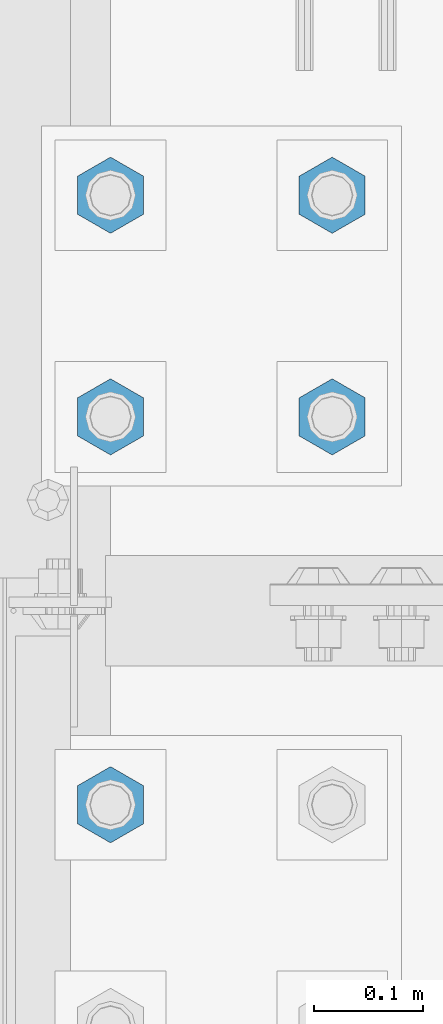
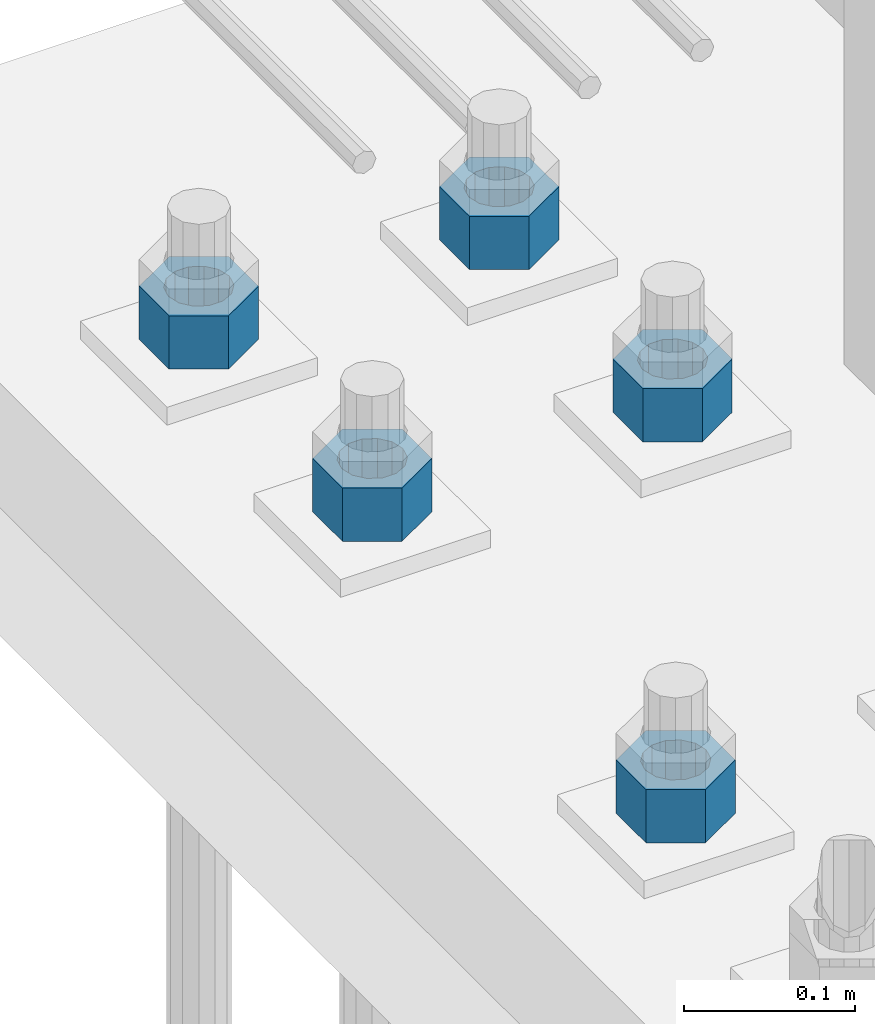
# One storey, part 1660 of 3843: 5 columns, 1 element without a shape of its own.
"""IFC2X3 building model written with IfcOpenShell, lengths in millimetres."""

from ifc_helpers import new_model, si_unit, frame, origin_with_axes, place, context, subcontext, project, spatial, faceted_brep, material, type_object, element, aggregate, save


model = new_model("IFC2X3")

# Units and contexts
model_context = context("Model", 3, precision=1e-05, world=origin_with_axes())
body_context = subcontext(model_context, "Body", "Model", "MODEL_VIEW")
ifc_project = project(units=[si_unit("LENGTHUNIT", "METRE", prefix="MILLI"), si_unit("AREAUNIT", "SQUARE_METRE"), si_unit("VOLUMEUNIT", "CUBIC_METRE"), si_unit("MASSUNIT", "GRAM", prefix="KILO"), si_unit("TIMEUNIT", "SECOND"), si_unit("PLANEANGLEUNIT", "RADIAN"), si_unit("SOLIDANGLEUNIT", "STERADIAN"), si_unit("THERMODYNAMICTEMPERATUREUNIT", "DEGREE_CELSIUS"), si_unit("LUMINOUSINTENSITYUNIT", "LUMEN")], contexts=[model_context])

# Site, building, storey
site_placement = place(None, origin_with_axes())
site = spatial("IfcSite", under=ifc_project, at=site_placement, CompositionType="ELEMENT")
building_placement = place(site_placement, origin_with_axes())
building = spatial("IfcBuilding", under=site, at=building_placement, Name="Undefined", CompositionType="ELEMENT")
storey_placement = place(building_placement, origin_with_axes())
storey = spatial("IfcBuildingStorey", under=building, at=storey_placement, Name="Undefined", CompositionType="ELEMENT", Elevation=0.0)

# Assembly, columns
assembly_placement = place(storey_placement, origin_with_axes())
assembly = element("IfcElementAssembly", 1, at=assembly_placement, inside=storey, Name="TEMPLATE", AssemblyPlace="NOTDEFINED", PredefinedType="RIGID_FRAME")
ifc_material = material(Name="STEEL/A572-50")
column_type = type_object("IfcColumnType", Name="1-1/2_HEAVY_HEX_NUT", PredefinedType="NOTDEFINED")
column_1_placement = place(assembly_placement, frame((76708.0, 15176.5, 30200.6), z_axis=(-1.0, 0.0, 0.0), x_axis=(0.0, 0.0, -1.0)))
column_1 = element("IfcColumn", 2, at=column_1_placement, type_object=column_type, material=ifc_material, Name="NUT", ObjectType="1-1/2_HEAVY_HEX_NUT", context=body_context, shape_type="Brep", body=[
    faceted_brep([(0.0, -34.9199981689453, 0.0), (0.0, -17.4599990844727, -30.25), (38.0999999999985, -17.4599990844727, -30.25), (38.0999999999985, -34.9199981689453, 0.0), (0.0, 17.4599990844727, -30.25), (38.0999999999985, 17.4599990844727, -30.25), (0.0, 34.9199981689453, 0.0), (38.0999999999985, 34.9199981689453, 0.0), (0.0, 17.4599990844727, 30.25), (38.0999999999985, 17.4599990844727, 30.25), (0.0, -17.4599990844727, 30.25), (38.0999999999985, -17.4599990844727, 30.25), (0.0, 0.0, 20.6399993896484), (0.0, 8.9553601105581, 18.5959968835959), (38.0999999999985, 8.9553601105581, 18.5959968835959), (38.0999999999985, 0.0, 20.6399993896484), (0.0, 16.1370013209525, 12.8688291298167), (38.0999999999985, 16.1370013209525, 12.8688291298167), (0.0, 20.1225115123816, 4.59283194104501), (38.0999999999985, 20.1225115123816, 4.59283194104501), (0.0, 20.1225115123816, -4.59283194104501), (38.0999999999985, 20.1225115123816, -4.59283194104501), (0.0, 16.1370013209525, -12.8688291298167), (38.0999999999985, 16.1370013209525, -12.8688291298167), (0.0, 8.9553601105581, -18.5959968835959), (38.0999999999985, 8.9553601105581, -18.5959968835959), (0.0, 0.0, -20.6399993896484), (38.0999999999985, 0.0, -20.6399993896484), (0.0, -8.9553601105581, -18.5959968835959), (38.0999999999985, -8.9553601105581, -18.5959968835959), (0.0, -16.1370013209525, -12.8688291298167), (38.0999999999985, -16.1370013209525, -12.8688291298167), (0.0, -20.1225115123816, -4.59283194104501), (38.0999999999985, -20.1225115123816, -4.59283194104501), (0.0, -20.1225115123816, 4.59283194104501), (38.0999999999985, -20.1225115123816, 4.59283194104501), (0.0, -16.1370013209525, 12.8688291298167), (38.0999999999985, -16.1370013209525, 12.8688291298167), (0.0, -8.9553601105581, 18.5959968835959), (38.0999999999985, -8.9553601105581, 18.5959968835959)], [[[0, 1, 2, 3]], [[1, 4, 5, 2]], [[4, 6, 7, 5]], [[6, 8, 9, 7]], [[8, 10, 11, 9]], [[10, 0, 3, 11]], [[12, 13, 14, 15]], [[13, 16, 17, 14]], [[16, 18, 19, 17]], [[18, 20, 21, 19]], [[20, 22, 23, 21]], [[22, 24, 25, 23]], [[24, 26, 27, 25]], [[26, 28, 29, 27]], [[28, 30, 31, 29]], [[30, 32, 33, 31]], [[32, 34, 35, 33]], [[34, 36, 37, 35]], [[36, 38, 39, 37]], [[38, 12, 15, 39]], [[5, 7, 9, 11, 3, 2], [17, 19, 21, 23, 25, 27, 29, 31, 33, 35, 37, 39, 15, 14]], [[10, 8, 6, 4, 1, 0], [38, 36, 34, 32, 30, 28, 26, 24, 22, 20, 18, 16, 13, 12]]]),
])
column_2_placement = place(assembly_placement, frame((76708.0, 15379.7, 30200.6), z_axis=(-1.0, 0.0, 0.0), x_axis=(0.0, 0.0, -1.0)))
column_2 = element("IfcColumn", 3, at=column_2_placement, type_object=column_type, material=ifc_material, Name="NUT", ObjectType="1-1/2_HEAVY_HEX_NUT", context=body_context, shape_type="Brep", body=[
    faceted_brep([(0.0, -34.9199981689453, 0.0), (0.0, -17.4599990844727, -30.25), (38.0999999999985, -17.4599990844727, -30.25), (38.0999999999985, -34.9199981689453, 0.0), (0.0, 17.4599990844727, -30.25), (38.0999999999985, 17.4599990844727, -30.25), (0.0, 34.9199981689453, 0.0), (38.0999999999985, 34.9199981689453, 0.0), (0.0, 17.4599990844727, 30.25), (38.0999999999985, 17.4599990844727, 30.25), (0.0, -17.4599990844727, 30.25), (38.0999999999985, -17.4599990844727, 30.25), (0.0, 0.0, 20.6399993896484), (0.0, 8.9553601105581, 18.5959968835959), (38.0999999999985, 8.9553601105581, 18.5959968835959), (38.0999999999985, 0.0, 20.6399993896484), (0.0, 16.1370013209525, 12.8688291298167), (38.0999999999985, 16.1370013209525, 12.8688291298167), (0.0, 20.1225115123816, 4.59283194104501), (38.0999999999985, 20.1225115123816, 4.59283194104501), (0.0, 20.1225115123816, -4.59283194104501), (38.0999999999985, 20.1225115123816, -4.59283194104501), (0.0, 16.1370013209525, -12.8688291298167), (38.0999999999985, 16.1370013209525, -12.8688291298167), (0.0, 8.9553601105581, -18.5959968835959), (38.0999999999985, 8.9553601105581, -18.5959968835959), (0.0, 0.0, -20.6399993896484), (38.0999999999985, 0.0, -20.6399993896484), (0.0, -8.9553601105581, -18.5959968835959), (38.0999999999985, -8.9553601105581, -18.5959968835959), (0.0, -16.1370013209525, -12.8688291298167), (38.0999999999985, -16.1370013209525, -12.8688291298167), (0.0, -20.1225115123816, -4.59283194104501), (38.0999999999985, -20.1225115123816, -4.59283194104501), (0.0, -20.1225115123816, 4.59283194104501), (38.0999999999985, -20.1225115123816, 4.59283194104501), (0.0, -16.1370013209525, 12.8688291298167), (38.0999999999985, -16.1370013209525, 12.8688291298167), (0.0, -8.9553601105581, 18.5959968835959), (38.0999999999985, -8.9553601105581, 18.5959968835959)], [[[0, 1, 2, 3]], [[1, 4, 5, 2]], [[4, 6, 7, 5]], [[6, 8, 9, 7]], [[8, 10, 11, 9]], [[10, 0, 3, 11]], [[12, 13, 14, 15]], [[13, 16, 17, 14]], [[16, 18, 19, 17]], [[18, 20, 21, 19]], [[20, 22, 23, 21]], [[22, 24, 25, 23]], [[24, 26, 27, 25]], [[26, 28, 29, 27]], [[28, 30, 31, 29]], [[30, 32, 33, 31]], [[32, 34, 35, 33]], [[34, 36, 37, 35]], [[36, 38, 39, 37]], [[38, 12, 15, 39]], [[5, 7, 9, 11, 3, 2], [17, 19, 21, 23, 25, 27, 29, 31, 33, 35, 37, 39, 15, 14]], [[10, 8, 6, 4, 1, 0], [38, 36, 34, 32, 30, 28, 26, 24, 22, 20, 18, 16, 13, 12]]]),
])
column_3_placement = place(assembly_placement, frame((76504.8, 14820.9, 30200.6), z_axis=(1.0, 0.0, 0.0), x_axis=(0.0, 0.0, -1.0)))
column_3 = element("IfcColumn", 4, at=column_3_placement, type_object=column_type, material=ifc_material, Name="NUT", ObjectType="1-1/2_HEAVY_HEX_NUT", context=body_context, shape_type="Brep", body=[
    faceted_brep([(0.0, -34.9199981689453, 0.0), (0.0, -17.4599990844727, -30.25), (38.0999999999985, -17.4599990844727, -30.25), (38.0999999999985, -34.9199981689453, 0.0), (0.0, 17.4599990844727, -30.25), (38.0999999999985, 17.4599990844727, -30.25), (0.0, 34.9199981689453, 0.0), (38.0999999999985, 34.9199981689453, 0.0), (0.0, 17.4599990844727, 30.25), (38.0999999999985, 17.4599990844727, 30.25), (0.0, -17.4599990844727, 30.25), (38.0999999999985, -17.4599990844727, 30.25), (0.0, 0.0, 20.6399993896484), (0.0, 8.9553601105581, 18.5959968835959), (38.0999999999985, 8.9553601105581, 18.5959968835959), (38.0999999999985, 0.0, 20.6399993896484), (0.0, 16.1370013209525, 12.8688291298167), (38.0999999999985, 16.1370013209525, 12.8688291298167), (0.0, 20.1225115123816, 4.59283194104501), (38.0999999999985, 20.1225115123816, 4.59283194104501), (0.0, 20.1225115123816, -4.59283194104501), (38.0999999999985, 20.1225115123816, -4.59283194104501), (0.0, 16.1370013209525, -12.8688291298167), (38.0999999999985, 16.1370013209525, -12.8688291298167), (0.0, 8.9553601105581, -18.5959968835959), (38.0999999999985, 8.9553601105581, -18.5959968835959), (0.0, 0.0, -20.6399993896484), (38.0999999999985, 0.0, -20.6399993896484), (0.0, -8.9553601105581, -18.5959968835959), (38.0999999999985, -8.9553601105581, -18.5959968835959), (0.0, -16.1370013209525, -12.8688291298167), (38.0999999999985, -16.1370013209525, -12.8688291298167), (0.0, -20.1225115123816, -4.59283194104501), (38.0999999999985, -20.1225115123816, -4.59283194104501), (0.0, -20.1225115123816, 4.59283194104501), (38.0999999999985, -20.1225115123816, 4.59283194104501), (0.0, -16.1370013209525, 12.8688291298167), (38.0999999999985, -16.1370013209525, 12.8688291298167), (0.0, -8.9553601105581, 18.5959968835959), (38.0999999999985, -8.9553601105581, 18.5959968835959)], [[[0, 1, 2, 3]], [[1, 4, 5, 2]], [[4, 6, 7, 5]], [[6, 8, 9, 7]], [[8, 10, 11, 9]], [[10, 0, 3, 11]], [[12, 13, 14, 15]], [[13, 16, 17, 14]], [[16, 18, 19, 17]], [[18, 20, 21, 19]], [[20, 22, 23, 21]], [[22, 24, 25, 23]], [[24, 26, 27, 25]], [[26, 28, 29, 27]], [[28, 30, 31, 29]], [[30, 32, 33, 31]], [[32, 34, 35, 33]], [[34, 36, 37, 35]], [[36, 38, 39, 37]], [[38, 12, 15, 39]], [[5, 7, 9, 11, 3, 2], [17, 19, 21, 23, 25, 27, 29, 31, 33, 35, 37, 39, 15, 14]], [[10, 8, 6, 4, 1, 0], [38, 36, 34, 32, 30, 28, 26, 24, 22, 20, 18, 16, 13, 12]]]),
])
column_4_placement = place(assembly_placement, frame((76504.8, 15176.5, 30200.6), z_axis=(-1.0, 0.0, 0.0), x_axis=(0.0, 0.0, -1.0)))
column_4 = element("IfcColumn", 5, at=column_4_placement, type_object=column_type, material=ifc_material, Name="NUT", ObjectType="1-1/2_HEAVY_HEX_NUT", context=body_context, shape_type="Brep", body=[
    faceted_brep([(0.0, -34.9199981689453, 0.0), (0.0, -17.4599990844727, -30.25), (38.0999999999985, -17.4599990844727, -30.25), (38.0999999999985, -34.9199981689453, 0.0), (0.0, 17.4599990844727, -30.25), (38.0999999999985, 17.4599990844727, -30.25), (0.0, 34.9199981689453, 0.0), (38.0999999999985, 34.9199981689453, 0.0), (0.0, 17.4599990844727, 30.25), (38.0999999999985, 17.4599990844727, 30.25), (0.0, -17.4599990844727, 30.25), (38.0999999999985, -17.4599990844727, 30.25), (0.0, 0.0, 20.6399993896484), (0.0, 8.9553601105581, 18.5959968835959), (38.0999999999985, 8.9553601105581, 18.5959968835959), (38.0999999999985, 0.0, 20.6399993896484), (0.0, 16.1370013209525, 12.8688291298167), (38.0999999999985, 16.1370013209525, 12.8688291298167), (0.0, 20.1225115123816, 4.59283194104501), (38.0999999999985, 20.1225115123816, 4.59283194104501), (0.0, 20.1225115123816, -4.59283194104501), (38.0999999999985, 20.1225115123816, -4.59283194104501), (0.0, 16.1370013209525, -12.8688291298167), (38.0999999999985, 16.1370013209525, -12.8688291298167), (0.0, 8.9553601105581, -18.5959968835959), (38.0999999999985, 8.9553601105581, -18.5959968835959), (0.0, 0.0, -20.6399993896484), (38.0999999999985, 0.0, -20.6399993896484), (0.0, -8.9553601105581, -18.5959968835959), (38.0999999999985, -8.9553601105581, -18.5959968835959), (0.0, -16.1370013209525, -12.8688291298167), (38.0999999999985, -16.1370013209525, -12.8688291298167), (0.0, -20.1225115123816, -4.59283194104501), (38.0999999999985, -20.1225115123816, -4.59283194104501), (0.0, -20.1225115123816, 4.59283194104501), (38.0999999999985, -20.1225115123816, 4.59283194104501), (0.0, -16.1370013209525, 12.8688291298167), (38.0999999999985, -16.1370013209525, 12.8688291298167), (0.0, -8.9553601105581, 18.5959968835959), (38.0999999999985, -8.9553601105581, 18.5959968835959)], [[[0, 1, 2, 3]], [[1, 4, 5, 2]], [[4, 6, 7, 5]], [[6, 8, 9, 7]], [[8, 10, 11, 9]], [[10, 0, 3, 11]], [[12, 13, 14, 15]], [[13, 16, 17, 14]], [[16, 18, 19, 17]], [[18, 20, 21, 19]], [[20, 22, 23, 21]], [[22, 24, 25, 23]], [[24, 26, 27, 25]], [[26, 28, 29, 27]], [[28, 30, 31, 29]], [[30, 32, 33, 31]], [[32, 34, 35, 33]], [[34, 36, 37, 35]], [[36, 38, 39, 37]], [[38, 12, 15, 39]], [[5, 7, 9, 11, 3, 2], [17, 19, 21, 23, 25, 27, 29, 31, 33, 35, 37, 39, 15, 14]], [[10, 8, 6, 4, 1, 0], [38, 36, 34, 32, 30, 28, 26, 24, 22, 20, 18, 16, 13, 12]]]),
])
column_5_placement = place(assembly_placement, frame((76504.8, 15379.7, 30200.6), z_axis=(-1.0, 0.0, 0.0), x_axis=(0.0, 0.0, -1.0)))
column_5 = element("IfcColumn", 6, at=column_5_placement, type_object=column_type, material=ifc_material, Name="NUT", ObjectType="1-1/2_HEAVY_HEX_NUT", context=body_context, shape_type="Brep", body=[
    faceted_brep([(0.0, -34.9199981689453, 0.0), (0.0, -17.4599990844727, -30.25), (38.0999999999985, -17.4599990844727, -30.25), (38.0999999999985, -34.9199981689453, 0.0), (0.0, 17.4599990844727, -30.25), (38.0999999999985, 17.4599990844727, -30.25), (0.0, 34.9199981689453, 0.0), (38.0999999999985, 34.9199981689453, 0.0), (0.0, 17.4599990844727, 30.25), (38.0999999999985, 17.4599990844727, 30.25), (0.0, -17.4599990844727, 30.25), (38.0999999999985, -17.4599990844727, 30.25), (0.0, 0.0, 20.6399993896484), (0.0, 8.9553601105581, 18.5959968835959), (38.0999999999985, 8.9553601105581, 18.5959968835959), (38.0999999999985, 0.0, 20.6399993896484), (0.0, 16.1370013209525, 12.8688291298167), (38.0999999999985, 16.1370013209525, 12.8688291298167), (0.0, 20.1225115123816, 4.59283194104501), (38.0999999999985, 20.1225115123816, 4.59283194104501), (0.0, 20.1225115123816, -4.59283194104501), (38.0999999999985, 20.1225115123816, -4.59283194104501), (0.0, 16.1370013209525, -12.8688291298167), (38.0999999999985, 16.1370013209525, -12.8688291298167), (0.0, 8.9553601105581, -18.5959968835959), (38.0999999999985, 8.9553601105581, -18.5959968835959), (0.0, 0.0, -20.6399993896484), (38.0999999999985, 0.0, -20.6399993896484), (0.0, -8.9553601105581, -18.5959968835959), (38.0999999999985, -8.9553601105581, -18.5959968835959), (0.0, -16.1370013209525, -12.8688291298167), (38.0999999999985, -16.1370013209525, -12.8688291298167), (0.0, -20.1225115123816, -4.59283194104501), (38.0999999999985, -20.1225115123816, -4.59283194104501), (0.0, -20.1225115123816, 4.59283194104501), (38.0999999999985, -20.1225115123816, 4.59283194104501), (0.0, -16.1370013209525, 12.8688291298167), (38.0999999999985, -16.1370013209525, 12.8688291298167), (0.0, -8.9553601105581, 18.5959968835959), (38.0999999999985, -8.9553601105581, 18.5959968835959)], [[[0, 1, 2, 3]], [[1, 4, 5, 2]], [[4, 6, 7, 5]], [[6, 8, 9, 7]], [[8, 10, 11, 9]], [[10, 0, 3, 11]], [[12, 13, 14, 15]], [[13, 16, 17, 14]], [[16, 18, 19, 17]], [[18, 20, 21, 19]], [[20, 22, 23, 21]], [[22, 24, 25, 23]], [[24, 26, 27, 25]], [[26, 28, 29, 27]], [[28, 30, 31, 29]], [[30, 32, 33, 31]], [[32, 34, 35, 33]], [[34, 36, 37, 35]], [[36, 38, 39, 37]], [[38, 12, 15, 39]], [[5, 7, 9, 11, 3, 2], [17, 19, 21, 23, 25, 27, 29, 31, 33, 35, 37, 39, 15, 14]], [[10, 8, 6, 4, 1, 0], [38, 36, 34, 32, 30, 28, 26, 24, 22, 20, 18, 16, 13, 12]]]),
])
aggregate(assembly, [column_1, column_2, column_3, column_4, column_5])

save(model, "model.ifc")
